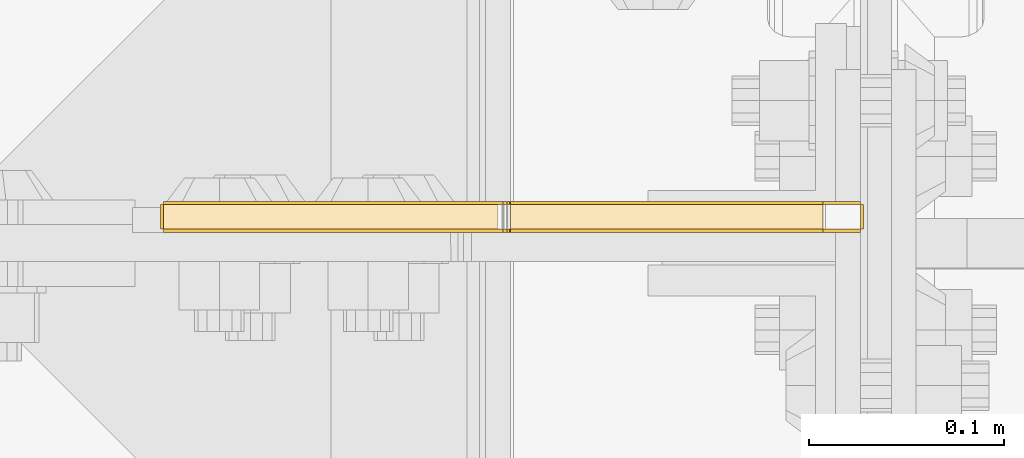
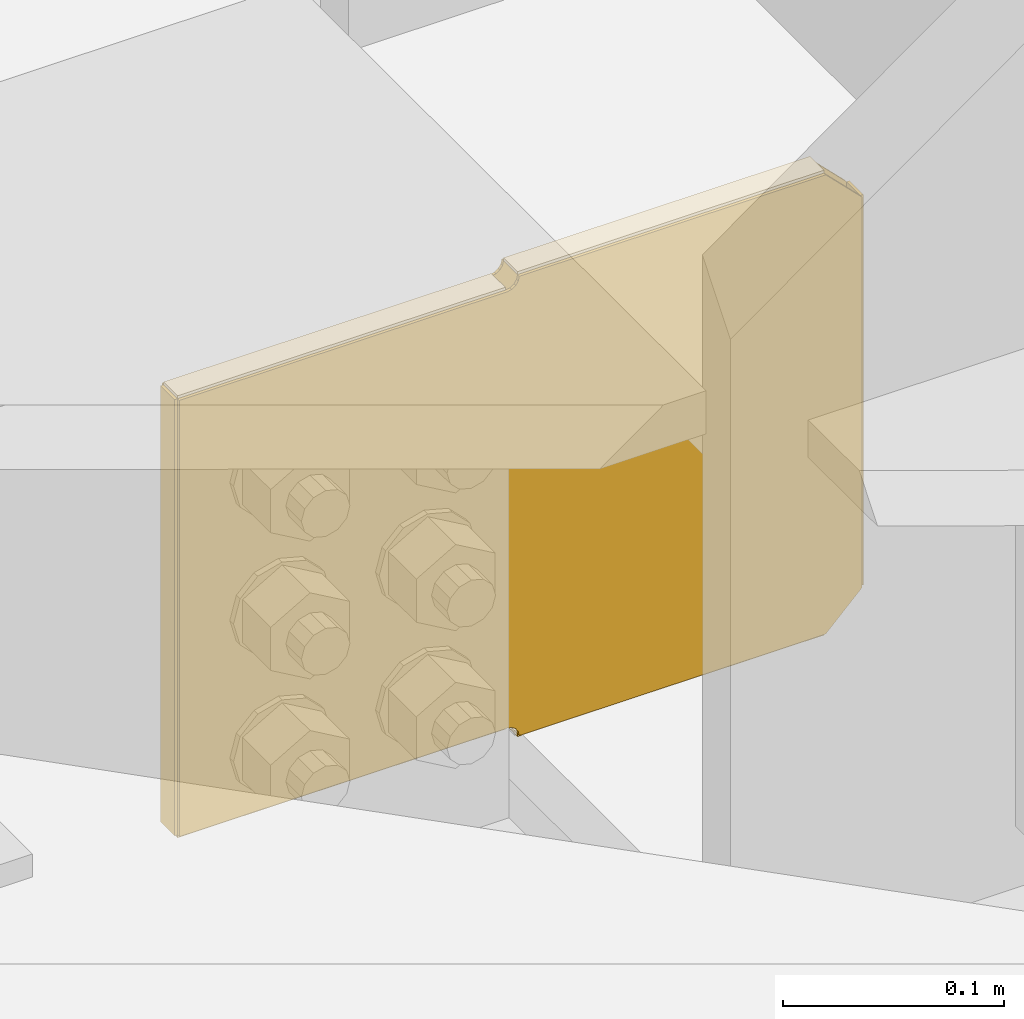
# One storey, part 3841 of 3843: 8 coverings.
"""IFC2X3 building model written with IfcOpenShell, lengths in millimetres."""

from ifc_helpers import new_model, si_unit, frame, origin_with_axes, place, context, subcontext, project, spatial, faceted_brep, material, element, save


model = new_model("IFC2X3")

# Units and contexts
model_context = context("Model", 3, precision=1e-05, world=origin_with_axes())
body_context = subcontext(model_context, "Body", "Model", "MODEL_VIEW")
ifc_project = project(units=[si_unit("LENGTHUNIT", "METRE", prefix="MILLI"), si_unit("AREAUNIT", "SQUARE_METRE"), si_unit("VOLUMEUNIT", "CUBIC_METRE"), si_unit("MASSUNIT", "GRAM", prefix="KILO"), si_unit("TIMEUNIT", "SECOND"), si_unit("PLANEANGLEUNIT", "RADIAN"), si_unit("SOLIDANGLEUNIT", "STERADIAN"), si_unit("THERMODYNAMICTEMPERATUREUNIT", "DEGREE_CELSIUS"), si_unit("LUMINOUSINTENSITYUNIT", "LUMEN")], contexts=[model_context])

# Site, building, storey
site_placement = place(None, origin_with_axes())
site = spatial("IfcSite", under=ifc_project, at=site_placement, CompositionType="ELEMENT")
building_placement = place(site_placement, origin_with_axes())
building = spatial("IfcBuilding", under=site, at=building_placement, Name="Undefined", CompositionType="ELEMENT")
storey_placement = place(building_placement, origin_with_axes())
storey = spatial("IfcBuildingStorey", under=building, at=storey_placement, Name="Undefined", CompositionType="ELEMENT", Elevation=0.0)

# Coverings
ifc_material = material(Name="Undefined/Undefined")
covering_1_placement = place(storey_placement, frame((85641.656, 84004.9437500954, 42162.1964771966), z_axis=(0.0, -1.0, 0.0), x_axis=(0.0, 0.0, 1.0)))
element("IfcCovering", 1, at=covering_1_placement, inside=storey, material=ifc_material, Name="SurfaceTreatment", PredefinedType="NOTDEFINED", context=body_context, shape_type="Brep", body=[
    faceted_brep([(0.0, -0.793499999999767, 12.7000000000116), (215.900042926245, -0.793499999999767, 12.7000000000116), (215.900042926245, 0.793499999999767, 12.7000000000116), (0.0, 0.793499999999767, 12.7000000000116), (215.900042926245, -0.793499999999767, 0.0), (215.900042926245, 0.793499999999767, 0.0), (-1.45519152283669e-11, -0.793499999999767, 0.0), (-1.45519152283669e-11, 0.793499999999767, 0.0)], [[[0, 1, 2, 3]], [[1, 4, 5, 2]], [[4, 6, 7, 5]], [[6, 0, 3, 7]], [[5, 7, 3, 2]], [[6, 4, 1, 0]]]),
])
covering_2_placement = place(storey_placement, frame((85621.8124999986, 84004.9437500954, 42397.9400201225), z_axis=(0.0, -1.0, 0.0), x_axis=(-1.0, 0.0, 0.0)))
element("IfcCovering", 2, at=covering_2_placement, inside=storey, material=ifc_material, Name="SurfaceTreatment", PredefinedType="NOTDEFINED", context=body_context, shape_type="Brep", body=[
    faceted_brep([(0.0, -0.793499999999767, 12.7000000000116), (160.337500002235, -0.79350000051636, 12.7000000000116), (160.337500002235, 0.793499999483174, 12.7000000000116), (0.0, 0.793499999999767, 12.7000000000116), (160.337500002235, -0.79350000051636, 0.0), (160.337500002235, 0.793499999483174, 0.0), (-1.45519152283669e-11, -0.793499999999767, 0.0), (-1.45519152283669e-11, 0.793499999999767, 0.0)], [[[0, 1, 2, 3]], [[1, 4, 5, 2]], [[4, 6, 7, 5]], [[6, 0, 3, 7]], [[5, 7, 3, 2]], [[6, 4, 1, 0]]]),
])
covering_3_placement = place(storey_placement, frame((85455.1035176249, 84004.9437500954, 42391.5685375754), z_axis=(0.0, -1.0, 0.0), x_axis=(-1.0, 0.0, 0.0)))
element("IfcCovering", 3, at=covering_3_placement, inside=storey, material=ifc_material, Name="SurfaceTreatment", PredefinedType="NOTDEFINED", context=body_context, shape_type="Brep", body=[
    faceted_brep([(0.0, -0.793499999999767, 12.7000000000116), (171.428517630484, -0.793499999999767, 12.7000000000116), (171.428517630484, 0.793499999999767, 12.7000000000116), (0.0, 0.793499999999767, 12.7000000000116), (171.428517630484, -0.793499999999767, 0.0), (171.428517630484, 0.793499999999767, 0.0), (-1.45519152283669e-11, -0.793499999999767, 0.0), (-1.45519152283669e-11, 0.793499999999767, 0.0)], [[[0, 1, 2, 3]], [[1, 4, 5, 2]], [[4, 6, 7, 5]], [[6, 0, 3, 7]], [[5, 7, 3, 2]], [[6, 4, 1, 0]]]),
])
covering_4_placement = place(storey_placement, frame((85282.8814999944, 84004.9437500954, 42390.7750375299), z_axis=(0.0, -1.0, 0.0), x_axis=(0.0, 0.0, -1.0)))
element("IfcCovering", 4, at=covering_4_placement, inside=storey, material=ifc_material, Name="SurfaceTreatment", PredefinedType="NOTDEFINED", context=body_context, shape_type="Brep", body=[
    faceted_brep([(0.0, -0.793499999999767, 12.7000000000116), (241.299999998839, -0.793499999999767, 12.7000000000116), (241.299999998839, 0.793499999999767, 12.7000000000116), (0.0, 0.793499999999767, 12.7000000000116), (241.299999998839, -0.793499999999767, 0.0), (241.299999998839, 0.793499999999767, 0.0), (-1.45519152283669e-11, -0.793499999999767, 0.0), (-1.45519152283669e-11, 0.793499999999767, 0.0)], [[[0, 1, 2, 3]], [[1, 4, 5, 2]], [[4, 6, 7, 5]], [[6, 0, 3, 7]], [[5, 7, 3, 2]], [[6, 4, 1, 0]]]),
])
covering_5_placement = place(storey_placement, frame((85283.6749999944, 84004.9437500954, 42148.6815375827), z_axis=(0.0, -1.0, 0.0), x_axis=(1.0, 0.0, 0.0)))
element("IfcCovering", 5, at=covering_5_placement, inside=storey, material=ifc_material, Name="SurfaceTreatment", PredefinedType="NOTDEFINED", context=body_context, shape_type="Brep", body=[
    faceted_brep([(0.0, -0.793499999999767, 12.7000000000116), (171.471439650428, -0.793499999999767, 12.7000000000116), (171.471439650428, 0.793499999999767, 12.7000000000116), (0.0, 0.793499999999767, 12.7000000000116), (171.471439650428, -0.793499999999767, 0.0), (171.471439650428, 0.793499999999767, 0.0), (-1.45519152283669e-11, -0.793499999999767, 0.0), (-1.45519152283669e-11, 0.793499999999767, 0.0)], [[[0, 1, 2, 3]], [[1, 4, 5, 2]], [[4, 6, 7, 5]], [[6, 0, 3, 7]], [[5, 7, 3, 2]], [[6, 4, 1, 0]]]),
])
covering_6_placement = place(storey_placement, frame((85461.4749999972, 84004.9437500954, 42142.3529772019), z_axis=(0.0, -1.0, 0.0), x_axis=(1.0, 0.0, 0.0)))
element("IfcCovering", 6, at=covering_6_placement, inside=storey, material=ifc_material, Name="SurfaceTreatment", PredefinedType="NOTDEFINED", context=body_context, shape_type="Brep", body=[
    faceted_brep([(0.0, -0.793499999999767, 12.7000000000116), (160.337500002235, -0.79350000051636, 12.7000000000116), (160.337500002235, 0.793499999483174, 12.7000000000116), (0.0, 0.793499999999767, 12.7000000000116), (160.337500002235, -0.79350000051636, 0.0), (160.337500002235, 0.793499999483174, 0.0), (-1.45519152283669e-11, -0.793499999999767, 0.0), (-1.45519152283669e-11, 0.793499999999767, 0.0)], [[[0, 1, 2, 3]], [[1, 4, 5, 2]], [[4, 6, 7, 5]], [[6, 0, 3, 7]], [[5, 7, 3, 2]], [[6, 4, 1, 0]]]),
])
covering_7_placement = place(storey_placement, frame((85621.8124999997, 83991.4502500954, 42397.1465201228), z_axis=(0.0, 0.0, -1.0), x_axis=(-1.0, 0.0, 0.0)))
element("IfcCovering", 7, at=covering_7_placement, inside=storey, material=ifc_material, Name="SurfaceTreatment", PredefinedType="NOTDEFINED", context=body_context, shape_type="Brep", body=[
    faceted_brep([(-19.0499999814492, -0.793499999999767, 19.0500000190223), (-19.0499997679872, -0.793499999999767, 234.950042945267), (-19.0499997679872, 0.793499999999767, 234.950042945267), (-19.0499999814492, 0.793499999999767, 19.0500000190223), (2.51151504926383e-07, -0.793499999999767, 254.000042926054), (2.51151504926383e-07, 0.793499999999767, 254.000042926054), (160.337500253678, -0.793499999999767, 254.000042765198), (160.337500253678, 0.793499999999767, 254.000042765198), (160.819233223825, -0.793499999999767, 251.578207585124), (160.819233223825, 0.793499999999767, 251.578207585124), (162.191092661305, -0.793499999999767, 249.525074841025), (162.191092661305, 0.793499999999767, 249.525074841025), (164.244225402683, -0.793499999999767, 248.15321539947), (164.244225402683, 0.793499999999767, 248.15321539947), (166.666060599789, -0.793499999999767, 247.671482424492), (166.666060599789, 0.793499999999767, 247.671482424492), (338.137500250217, -0.793499999999767, 247.671482252466), (338.137500250217, 0.793499999999767, 247.671482252466), (338.137500011653, -0.793499999999767, 6.37148225362762), (338.137500011653, 0.793499999999767, 6.37148225362762), (166.708982381169, -0.793499999999767, 6.37148242560943), (166.708982381169, 0.793499999999767, 6.37148242560943), (164.270721637193, -0.793499999999767, 5.88648221128824), (164.270721637193, 0.793499999999767, 5.88648221128824), (162.203663987631, -0.793499999999767, 4.50531844951183), (162.203663987631, 0.793499999999767, 4.50531844951183), (160.822500221722, -0.793499999999767, 2.43826080272993), (160.822500221722, 0.793499999999767, 2.43826080272993), (160.337500002235, -0.79350000051636, 0.0), (160.337500002235, 0.793499999483174, 0.0), (-1.45519152283669e-11, -0.793499999999767, 0.0), (-1.45519152283669e-11, 0.793499999999767, 0.0)], [[[0, 1, 2, 3]], [[1, 4, 5, 2]], [[4, 6, 7, 5]], [[6, 8, 9, 7]], [[8, 10, 11, 9]], [[10, 12, 13, 11]], [[12, 14, 15, 13]], [[14, 16, 17, 15]], [[16, 18, 19, 17]], [[18, 20, 21, 19]], [[20, 22, 23, 21]], [[22, 24, 25, 23]], [[24, 26, 27, 25]], [[26, 28, 29, 27]], [[28, 30, 31, 29]], [[30, 0, 3, 31]], [[5, 7, 9, 11, 13, 15, 17, 19, 21, 23, 25, 27, 29, 31, 3, 2]], [[30, 28, 26, 24, 22, 20, 18, 16, 14, 12, 10, 8, 6, 4, 1, 0]]]),
])
covering_8_placement = place(storey_placement, frame((85621.8124999997, 84005.7372500954, 42143.1464771967), z_axis=(0.0, 0.0, 1.0), x_axis=(-1.0, 0.0, 0.0)))
element("IfcCovering", 8, at=covering_8_placement, inside=storey, material=ifc_material, Name="SurfaceTreatment", PredefinedType="NOTDEFINED", context=body_context, shape_type="Brep", body=[
    faceted_brep([(-19.0499999814492, -0.793499999999767, 19.0500000190223), (-19.0499997679872, -0.793499999999767, 234.950042945267), (-19.0499997679872, 0.793499999999767, 234.950042945267), (-19.0499999814492, 0.793499999999767, 19.0500000190223), (2.51151504926383e-07, -0.793499999999767, 254.000042926054), (2.51151504926383e-07, 0.793499999999767, 254.000042926054), (160.337500253678, -0.793499999999767, 254.000042765198), (160.337500253678, 0.793499999999767, 254.000042765198), (160.822500219307, -0.793499999999767, 251.56178196198), (160.822500219307, 0.793499999999767, 251.56178196198), (162.203663983179, -0.793499999999767, 249.494724313816), (162.203663983179, 0.793499999999767, 249.494724313816), (164.270721631357, -0.793499999999767, 248.113560549966), (164.270721631357, 0.793499999999767, 248.113560549966), (166.708982374854, -0.793499999999767, 247.628560333193), (166.708982374854, 0.793499999999767, 247.628560333193), (338.137500005338, -0.793499999999767, 247.628560333193), (338.137500005338, 0.793499999999767, 247.628560333193), (338.137500005338, -0.793499999999767, 6.32856033435382), (338.137500005338, 0.793499999999767, 6.32856033435382), (166.66606035491, -0.793499999999767, 6.32856033435382), (166.66606035491, 0.793499999999767, 6.32856033435382), (164.244225157337, -0.793499999999767, 5.84682736180548), (164.244225157337, 0.793499999999767, 5.84682736180548), (162.191092414592, -0.793499999999767, 4.47496792230959), (162.191092414592, 0.793499999999767, 4.47496792230959), (160.819232975089, -0.793499999999767, 2.42183517959347), (160.819232975089, 0.793499999999767, 2.42183517959347), (160.337500002235, -0.79350000051636, 0.0), (160.337500002235, 0.793499999483174, 0.0), (-1.45519152283669e-11, -0.793499999999767, 0.0), (-1.45519152283669e-11, 0.793499999999767, 0.0)], [[[0, 1, 2, 3]], [[1, 4, 5, 2]], [[4, 6, 7, 5]], [[6, 8, 9, 7]], [[8, 10, 11, 9]], [[10, 12, 13, 11]], [[12, 14, 15, 13]], [[14, 16, 17, 15]], [[16, 18, 19, 17]], [[18, 20, 21, 19]], [[20, 22, 23, 21]], [[22, 24, 25, 23]], [[24, 26, 27, 25]], [[26, 28, 29, 27]], [[28, 30, 31, 29]], [[30, 0, 3, 31]], [[5, 7, 9, 11, 13, 15, 17, 19, 21, 23, 25, 27, 29, 31, 3, 2]], [[30, 28, 26, 24, 22, 20, 18, 16, 14, 12, 10, 8, 6, 4, 1, 0]]]),
])

save(model, "model.ifc")
